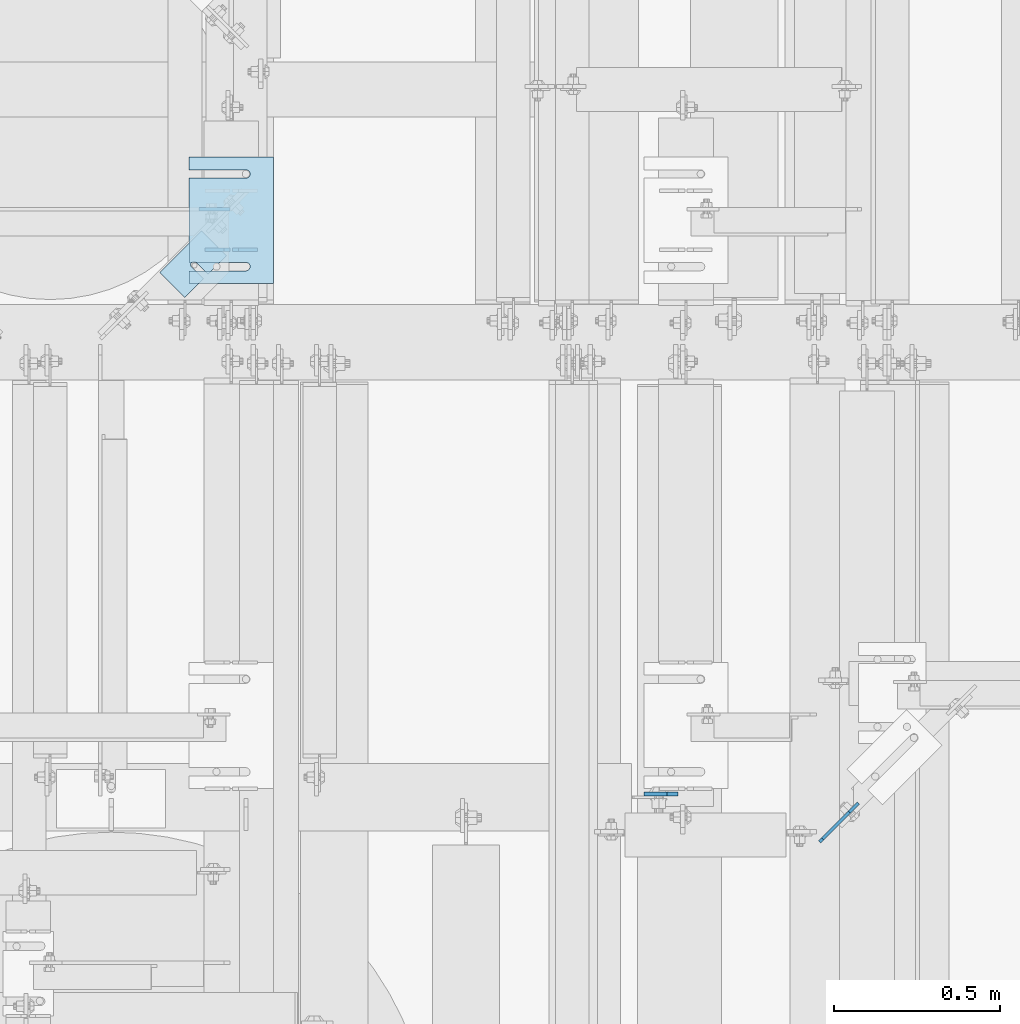
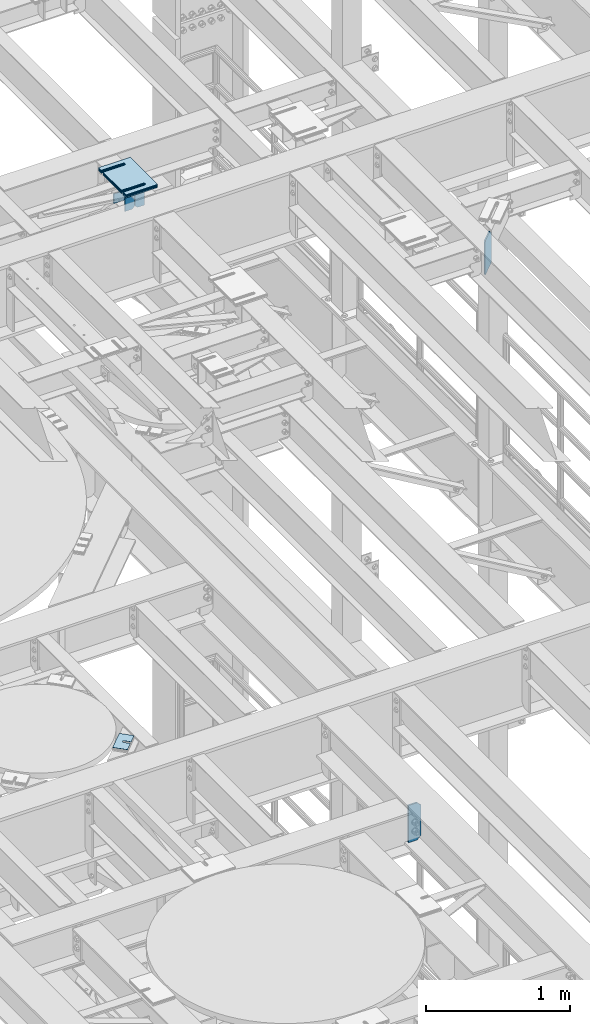
# One storey, part 1718 of 1876: 12 plates, 10 elements without a shape of their own.
"""IFC2X3 building model written with IfcOpenShell, lengths in millimetres."""

from ifc_helpers import new_model, si_unit, frame, origin_with_axes, place, context, subcontext, project, spatial, faceted_brep, material, type_object, element, aggregate, save


model = new_model("IFC2X3")

# Units and contexts
model_context = context("Model", 3, precision=1e-05, world=origin_with_axes())
body_context = subcontext(model_context, "Body", "Model", "MODEL_VIEW")
ifc_project = project(units=[si_unit("LENGTHUNIT", "METRE", prefix="MILLI"), si_unit("AREAUNIT", "SQUARE_METRE"), si_unit("VOLUMEUNIT", "CUBIC_METRE"), si_unit("MASSUNIT", "GRAM", prefix="KILO"), si_unit("TIMEUNIT", "SECOND"), si_unit("PLANEANGLEUNIT", "RADIAN"), si_unit("SOLIDANGLEUNIT", "STERADIAN"), si_unit("THERMODYNAMICTEMPERATUREUNIT", "DEGREE_CELSIUS"), si_unit("LUMINOUSINTENSITYUNIT", "LUMEN")], contexts=[model_context])

# Site, building, storey
site_placement = place(None, origin_with_axes())
site = spatial("IfcSite", under=ifc_project, at=site_placement, CompositionType="ELEMENT")
building_placement = place(site_placement, origin_with_axes())
building = spatial("IfcBuilding", under=site, at=building_placement, Name="Undefined", CompositionType="ELEMENT")
storey_placement = place(building_placement, origin_with_axes())
storey = spatial("IfcBuildingStorey", under=building, at=storey_placement, Name="Undefined", CompositionType="ELEMENT", Elevation=0.0)

# Assembly, plates
assembly_1_placement = place(storey_placement, origin_with_axes())
assembly_1 = element("IfcElementAssembly", 1, at=assembly_1_placement, inside=storey, Name="BEAM", AssemblyPlace="NOTDEFINED", PredefinedType="RIGID_FRAME")
ifc_material = material(Name="STEEL/A36")
plate_type_1 = type_object("IfcPlateType", PredefinedType="NOTDEFINED")
plate_1_placement = place(assembly_1_placement, frame((3813.17530602581, 7898.88122576401, 17792.7), z_axis=(0.0, 0.0, 1.0), x_axis=(-1.0, 0.0, 0.0)))
plate_1 = element("IfcPlate", 2, at=plate_1_placement, type_object=plate_type_1, material=ifc_material, Name="PLATE", context=body_context, shape_type="Brep", body=[
    faceted_brep([(0.0, -4.76249999999982, 0.0), (0.0, -4.76249999999982, 180.975006103516), (0.0, 4.76249999999982, 180.975006103516), (0.0, 4.76249999999982, 0.0), (57.1499977111816, -4.76249999999982, 180.975006103516), (57.1499977111816, 4.76249999999982, 180.975006103516), (76.1999969482422, -4.76249999999982, 161.925006866455), (76.1999969482422, 4.76249999999982, 161.925006866455), (76.1999969482422, -4.76249999999982, 19.0499992370605), (76.1999969482422, 4.76249999999982, 19.0499992370605), (57.1499977111816, -4.76249999999982, 0.0), (57.1499977111816, 4.76249999999982, 0.0)], [[[0, 1, 2, 3]], [[1, 4, 5, 2]], [[4, 6, 7, 5]], [[6, 8, 9, 7]], [[8, 10, 11, 9]], [[10, 0, 3, 11]], [[5, 7, 9, 11, 3, 2]], [[10, 8, 6, 4, 1, 0]]]),
])
plate_2_placement = place(assembly_1_placement, frame((3730.62530602581, 7898.88122576401, 17792.7), z_axis=(0.0, 0.0, 1.0), x_axis=(-1.0, 0.0, 0.0)))
plate_2 = element("IfcPlate", 3, at=plate_2_placement, type_object=plate_type_1, material=ifc_material, Name="PLATE", context=body_context, shape_type="Brep", body=[
    faceted_brep([(0.0, -4.76249999999982, 19.0499992370605), (0.0, -4.76249999999982, 161.925006866455), (0.0, 4.76249999999982, 161.925006866455), (0.0, 4.76249999999982, 19.0499992370605), (19.0499992370605, -4.76249999999982, 180.975006103516), (19.0499992370605, 4.76249999999982, 180.975006103516), (76.1999969482422, -4.76249999999982, 180.975006103516), (76.1999969482422, 4.76249999999982, 180.975006103516), (76.1999969482422, -4.76250000000073, 0.0), (76.1999969482422, 4.76250000000073, 0.0), (19.0499992370605, -4.76249999999982, 0.0), (19.0499992370605, 4.76249999999982, 0.0)], [[[0, 1, 2, 3]], [[1, 4, 5, 2]], [[4, 6, 7, 5]], [[6, 8, 9, 7]], [[8, 10, 11, 9]], [[10, 0, 3, 11]], [[5, 7, 9, 11, 3, 2]], [[10, 8, 6, 4, 1, 0]]]),
])
plate_type_2 = type_object("IfcPlateType", PredefinedType="NOTDEFINED")
plate_3_placement = place(assembly_1_placement, frame((3636.43608330879, 8021.04472066874, 17872.884434622), z_axis=(1.0, 0.0, 0.0), x_axis=(0.0, 0.0, -1.0)))
plate_3 = element("IfcPlate", 4, at=plate_3_placement, type_object=plate_type_2, material=ifc_material, Name="PLATE", context=body_context, shape_type="Brep", body=[
    faceted_brep([(0.0, -4.76249999999982, 0.0), (-4.72590436402243e-05, -4.76250000001801, 94.1892242431759), (-4.72590436402243e-05, 4.76249999998163, 94.1892242431773), (0.0, 4.76249999999982, 0.0), (67.4843873978753, -4.76250000001892, 94.1892820322919), (67.4843873978753, 4.76249999998072, 94.1892820322932), (80.1843933793753, -4.76250000001528, 81.4892930984493), (80.1843933793753, 4.76249999998436, 81.4892930984511), (80.1844329834057, -4.76249999999982, 1.16870069177821e-10), (80.1844329834057, 4.76249999999982, 1.18689058581367e-10)], [[[0, 1, 2, 3]], [[1, 4, 5, 2]], [[4, 6, 7, 5]], [[6, 8, 9, 7]], [[8, 0, 3, 9]], [[5, 7, 9, 3, 2]], [[8, 6, 4, 1, 0]]]),
])
aggregate(assembly_1, [plate_1, plate_2, plate_3])

# Assembly, plate
assembly_2_placement = place(storey_placement, origin_with_axes())
assembly_2 = element("IfcElementAssembly", 5, at=assembly_2_placement, inside=storey, Name="BEAM", AssemblyPlace="NOTDEFINED", PredefinedType="RIGID_FRAME")
plate_type_3 = type_object("IfcPlateType", PredefinedType="NOTDEFINED")
plate_4_placement = place(assembly_2_placement, frame((5080.79375, 6257.13125009537, 12974.6375), z_axis=(0.0, 0.0, 1.0), x_axis=(-1.0, 0.0, 0.0)))
plate_4 = element("IfcPlate", 6, at=plate_4_placement, type_object=plate_type_3, material=ifc_material, Name="PLATE", context=body_context, shape_type="Brep", body=[
    faceted_brep([(0.0, -6.34999999999991, 31.75), (-1.81898940354586e-12, -6.34999999999991, 284.162506103516), (1.81898940354586e-12, 6.35000000000173, 284.162506103516), (0.0, 6.34999999999991, 31.75), (31.7499999999927, -6.34999999999991, 315.912506103516), (31.7499999999982, 6.35000000000309, 315.912506103516), (101.599998474121, -6.35000000000036, 315.912506103516), (101.599998474121, 6.35000000000036, 315.912506103516), (101.599998474121, -6.35000000000036, 0.0), (101.599998474121, 6.35000000000036, 0.0), (31.75, -6.34999999999991, 0.0), (31.75, 6.34999999999991, 0.0)], [[[0, 1, 2, 3]], [[1, 4, 5, 2]], [[4, 6, 7, 5]], [[6, 8, 9, 7]], [[8, 10, 11, 9]], [[10, 0, 3, 11]], [[5, 7, 9, 11, 3, 2]], [[10, 8, 6, 4, 1, 0]]]),
])
aggregate(assembly_2, [plate_4])

assembly_3_placement = place(storey_placement, origin_with_axes())
assembly_3 = element("IfcElementAssembly", 7, at=assembly_3_placement, inside=storey, Name="SHIM PLATE", AssemblyPlace="NOTDEFINED", PredefinedType="RIGID_FRAME")
plate_type_4 = type_object("IfcPlateType", PredefinedType="NOTDEFINED")
plate_5_placement = place(assembly_3_placement, frame((3860.80063238647, 8178.20543274993, 18007.0115), z_axis=(-1.0, 0.0, 0.0), x_axis=(0.0, -1.0, 0.0)))
plate_5 = element("IfcPlate", 8, at=plate_5_placement, type_object=plate_type_4, material=ifc_material, Name="SHIM PLATE", context=body_context, shape_type="Brep", body=[
    faceted_brep([(38.1710562683074, -1.58750000000146, 253.999557495119), (38.1732778844053, -1.58750000000146, 82.6182316462764), (38.1732778844053, 1.58750000000146, 82.6182316462764), (38.1710562683074, 1.58750000000146, 253.999557495119), (39.8747477728821, -1.58750000000146, 76.2682283464169), (39.8747477728821, 1.58750000000146, 76.2682283464169), (44.523266268131, -1.58750000000146, 71.6196998169826), (44.523266268131, 1.58750000000146, 71.6196998169826), (50.8732658952267, -1.58750000000146, 69.9182162215529), (50.8732658952267, 1.58750000000146, 69.9182162215529), (57.2232684284982, -1.58750000000146, 71.6196889709886), (57.2232684284982, 1.58750000000146, 71.6196889709886), (61.8717948635667, -1.58750000000146, 76.2682095606051), (61.8717948635667, 1.58750000000146, 76.2682095606051), (63.5732755980398, -1.58750000000146, 82.6182099542939), (63.5732755980398, 1.58750000000146, 82.6182099542939), (63.5710539816291, -1.58750000000146, 253.999557596195), (63.5710539816291, 1.58750000000146, 253.99955749512), (9.09494701772928e-13, -1.58750000000146, 4.54747350886464e-13), (1.89071320164658e-05, -1.58750000000146, 253.999557495117), (1.89071320164658e-05, 1.58750000000146, 253.999557495117), (9.09494701772928e-13, 1.58750000000146, 4.54747350886464e-13), (380.998474121094, -1.58750000000146, -2.41016095969826e-11), (380.998474121094, 1.58750000000146, -2.41016095969826e-11), (380.998504638661, -1.58750000000146, 253.999557495133), (380.998504638661, 1.58750000000146, 253.999557495133), (342.971054337228, 1.58750000000146, 253.999557495132), (342.971054337228, -1.58750000000146, 253.999557596208), (342.973275782132, 1.58750000000146, 82.6182252130961), (342.973275782132, -1.58750000000146, 82.6182252130961), (341.271801399192, 1.58750000000146, 76.2682205744086), (341.271801399192, -1.58750000000146, 76.2682205744086), (336.623277411347, 1.58750000000146, 71.6196940636119), (336.623277411347, -1.58750000000146, 71.6196940636119), (330.273273696123, 1.58750000000146, 69.9182162342554), (330.273273696123, -1.58750000000146, 69.9182162342554), (323.923270846187, 1.58750000000146, 71.6196972929051), (323.923270846187, -1.58750000000146, 71.6196972929051), (319.274749222349, 1.58750000000146, 76.2682261677069), (319.274749222349, -1.58750000000146, 76.2682261677069), (317.573278068704, 1.58750000000146, 82.6182316716777), (317.573278068704, -1.58750000000146, 82.6182316716777), (317.571056623908, -1.58750000000146, 253.99955749513), (317.571056623908, 1.58750000000146, 253.99955749513)], [[[0, 1, 2, 3]], [[4, 5, 2, 1]], [[6, 7, 5, 4]], [[8, 9, 7, 6]], [[10, 11, 9, 8]], [[12, 13, 11, 10]], [[14, 15, 13, 12]], [[16, 17, 15, 14]], [[18, 19, 20, 21]], [[22, 18, 21, 23]], [[24, 22, 23, 25]], [[24, 25, 26, 27]], [[27, 26, 28, 29]], [[29, 28, 30, 31]], [[31, 30, 32, 33]], [[33, 32, 34, 35]], [[35, 34, 36, 37]], [[37, 36, 38, 39]], [[39, 38, 40, 41]], [[42, 41, 40, 43]], [[12, 10, 8, 6, 4, 1, 0, 19, 18, 22, 24, 27, 29, 31, 33, 35, 37, 39, 41, 42, 16, 14]], [[20, 19, 0, 3]], [[43, 40, 38, 36, 34, 32, 30, 28, 26, 25, 23, 21, 20, 3, 2, 5, 7, 9, 11, 13, 15, 17]], [[42, 43, 17, 16]]]),
])
aggregate(assembly_3, [plate_5])

assembly_4_placement = place(storey_placement, origin_with_axes())
assembly_4 = element("IfcElementAssembly", 9, at=assembly_4_placement, inside=storey, Name="SHIM PLATE", AssemblyPlace="NOTDEFINED", PredefinedType="RIGID_FRAME")
plate_6_placement = place(assembly_4_placement, frame((3860.80063238647, 8178.20543274993, 18003.8365), z_axis=(-1.0, 0.0, 0.0), x_axis=(0.0, -1.0, 0.0)))
plate_6 = element("IfcPlate", 10, at=plate_6_placement, type_object=plate_type_4, material=ifc_material, Name="SHIM PLATE", context=body_context, shape_type="Brep", body=[
    faceted_brep([(38.1710562683074, -1.58750000000146, 253.999557495119), (38.1732778844053, -1.58750000000146, 82.6182316462764), (38.1732778844053, 1.58750000000146, 82.6182316462764), (38.1710562683074, 1.58750000000146, 253.999557495119), (39.8747477728821, -1.58750000000146, 76.2682283464169), (39.8747477728821, 1.58750000000146, 76.2682283464169), (44.523266268131, -1.58750000000146, 71.6196998169826), (44.523266268131, 1.58750000000146, 71.6196998169826), (50.8732658952267, -1.58750000000146, 69.9182162215529), (50.8732658952267, 1.58750000000146, 69.9182162215529), (57.2232684284982, -1.58750000000146, 71.6196889709886), (57.2232684284982, 1.58750000000146, 71.6196889709886), (61.8717948635667, -1.58750000000146, 76.2682095606051), (61.8717948635667, 1.58750000000146, 76.2682095606051), (63.5732755980398, -1.58750000000146, 82.6182099542939), (63.5732755980398, 1.58750000000146, 82.6182099542939), (63.5710539816291, -1.58750000000146, 253.999557596195), (63.5710539816291, 1.58750000000146, 253.99955749512), (9.09494701772928e-13, -1.58750000000146, 4.54747350886464e-13), (1.89071320164658e-05, -1.58750000000146, 253.999557495117), (1.89071320164658e-05, 1.58750000000146, 253.999557495117), (9.09494701772928e-13, 1.58750000000146, 4.54747350886464e-13), (380.998474121094, -1.58750000000146, -2.41016095969826e-11), (380.998474121094, 1.58750000000146, -2.41016095969826e-11), (380.998504638661, -1.58750000000146, 253.999557495133), (380.998504638661, 1.58750000000146, 253.999557495133), (342.971054337228, 1.58750000000146, 253.999557495132), (342.971054337228, -1.58750000000146, 253.999557596208), (342.973275782132, 1.58750000000146, 82.6182252130961), (342.973275782132, -1.58750000000146, 82.6182252130961), (341.271801399192, 1.58750000000146, 76.2682205744086), (341.271801399192, -1.58750000000146, 76.2682205744086), (336.623277411347, 1.58750000000146, 71.6196940636119), (336.623277411347, -1.58750000000146, 71.6196940636119), (330.273273696123, 1.58750000000146, 69.9182162342554), (330.273273696123, -1.58750000000146, 69.9182162342554), (323.923270846187, 1.58750000000146, 71.6196972929051), (323.923270846187, -1.58750000000146, 71.6196972929051), (319.274749222349, 1.58750000000146, 76.2682261677069), (319.274749222349, -1.58750000000146, 76.2682261677069), (317.573278068704, 1.58750000000146, 82.6182316716777), (317.573278068704, -1.58750000000146, 82.6182316716777), (317.571056623908, -1.58750000000146, 253.99955749513), (317.571056623908, 1.58750000000146, 253.99955749513)], [[[0, 1, 2, 3]], [[4, 5, 2, 1]], [[6, 7, 5, 4]], [[8, 9, 7, 6]], [[10, 11, 9, 8]], [[12, 13, 11, 10]], [[14, 15, 13, 12]], [[16, 17, 15, 14]], [[18, 19, 20, 21]], [[22, 18, 21, 23]], [[24, 22, 23, 25]], [[24, 25, 26, 27]], [[27, 26, 28, 29]], [[29, 28, 30, 31]], [[31, 30, 32, 33]], [[33, 32, 34, 35]], [[35, 34, 36, 37]], [[37, 36, 38, 39]], [[39, 38, 40, 41]], [[42, 41, 40, 43]], [[12, 10, 8, 6, 4, 1, 0, 19, 18, 22, 24, 27, 29, 31, 33, 35, 37, 39, 41, 42, 16, 14]], [[20, 19, 0, 3]], [[43, 40, 38, 36, 34, 32, 30, 28, 26, 25, 23, 21, 20, 3, 2, 5, 7, 9, 11, 13, 15, 17]], [[42, 43, 17, 16]]]),
])
aggregate(assembly_4, [plate_6])

assembly_5_placement = place(storey_placement, origin_with_axes())
assembly_5 = element("IfcElementAssembly", 11, at=assembly_5_placement, inside=storey, Name="SHIM PLATE", AssemblyPlace="NOTDEFINED", PredefinedType="RIGID_FRAME")
plate_type_5 = type_object("IfcPlateType", PredefinedType="NOTDEFINED")
plate_7_placement = place(assembly_5_placement, frame((3860.80063238647, 8178.20543274993, 18009.3925), z_axis=(-1.0, 0.0, 0.0), x_axis=(0.0, -1.0, 0.0)))
plate_7 = element("IfcPlate", 12, at=plate_7_placement, type_object=plate_type_5, material=ifc_material, Name="SHIM PLATE", context=body_context, shape_type="Brep", body=[
    faceted_brep([(38.1710562683074, -0.793499999999767, 253.999557495119), (38.1732778844053, -0.793499999999767, 82.6182316462764), (38.1732778844053, 0.793499999999767, 82.6182316462764), (38.1710562683074, 0.793499999999767, 253.999557495119), (39.8747477728821, -0.793499999999767, 76.2682283464169), (39.8747477728821, 0.793499999999767, 76.2682283464169), (44.523266268131, -0.793499999999767, 71.6196998169826), (44.523266268131, 0.793499999999767, 71.6196998169826), (50.8732658952267, -0.793499999999767, 69.9182162215529), (50.8732658952267, 0.793499999999767, 69.9182162215529), (57.2232684284982, -0.793499999999767, 71.6196889709886), (57.2232684284982, 0.793499999999767, 71.6196889709886), (61.8717948635667, -0.793499999999767, 76.2682095606051), (61.8717948635667, 0.793499999999767, 76.2682095606051), (63.5732755980398, -0.793499999999767, 82.6182099542939), (63.5732755980398, 0.793499999999767, 82.6182099542939), (63.5710539816291, -0.793499999999767, 253.999557596195), (63.5710539816291, 0.793499999999767, 253.99955749512), (9.09494701772928e-13, -0.793499999999767, 0.0), (1.89070156011439e-05, -0.793499999999767, 253.999557495117), (1.89070156011439e-05, 0.793499999999767, 253.999557495117), (9.09494701772928e-13, 0.793499999999767, 0.0), (380.998474121094, -0.793499999999767, -2.41016095969826e-11), (380.998474121094, 0.793499999999767, -2.41016095969826e-11), (380.998504638661, -0.793499999999767, 253.999557495133), (380.998504638661, 0.793499999999767, 253.999557495133), (342.971054337228, 0.793499999999767, 253.999557495132), (342.971054337228, -0.793499999999767, 253.999557596208), (342.973275782132, 0.793499999999767, 82.6182252130961), (342.973275782132, -0.793499999999767, 82.6182252130961), (341.271801399192, 0.793499999999767, 76.2682205744086), (341.271801399192, -0.793499999999767, 76.2682205744086), (336.623277411347, 0.793499999999767, 71.6196940636119), (336.623277411347, -0.793499999999767, 71.6196940636119), (330.273273696123, 0.793499999999767, 69.9182162342554), (330.273273696123, -0.793499999999767, 69.9182162342554), (323.923270846187, 0.793499999999767, 71.6196972929051), (323.923270846187, -0.793499999999767, 71.6196972929051), (319.274749222349, 0.793499999999767, 76.2682261677069), (319.274749222349, -0.793499999999767, 76.2682261677069), (317.573278068704, 0.793499999999767, 82.6182316716777), (317.573278068704, -0.793499999999767, 82.6182316716777), (317.571056623908, -0.793499999999767, 253.99955749513), (317.571056623908, 0.793499999999767, 253.99955749513)], [[[0, 1, 2, 3]], [[4, 5, 2, 1]], [[6, 7, 5, 4]], [[8, 9, 7, 6]], [[10, 11, 9, 8]], [[12, 13, 11, 10]], [[14, 15, 13, 12]], [[16, 17, 15, 14]], [[18, 19, 20, 21]], [[22, 18, 21, 23]], [[24, 22, 23, 25]], [[24, 25, 26, 27]], [[27, 26, 28, 29]], [[29, 28, 30, 31]], [[31, 30, 32, 33]], [[33, 32, 34, 35]], [[35, 34, 36, 37]], [[37, 36, 38, 39]], [[39, 38, 40, 41]], [[42, 41, 40, 43]], [[12, 10, 8, 6, 4, 1, 0, 19, 18, 22, 24, 27, 29, 31, 33, 35, 37, 39, 41, 42, 16, 14]], [[20, 19, 0, 3]], [[43, 40, 38, 36, 34, 32, 30, 28, 26, 25, 23, 21, 20, 3, 2, 5, 7, 9, 11, 13, 15, 17]], [[42, 43, 17, 16]]]),
])
aggregate(assembly_5, [plate_7])

assembly_6_placement = place(storey_placement, origin_with_axes())
assembly_6 = element("IfcElementAssembly", 13, at=assembly_6_placement, inside=storey, Name="SHIM PLATE", AssemblyPlace="NOTDEFINED", PredefinedType="RIGID_FRAME")
plate_type_6 = type_object("IfcPlateType", PredefinedType="NOTDEFINED")
plate_8_placement = place(assembly_6_placement, frame((3860.80063238647, 8178.20543274993, 17999.868), z_axis=(-1.0, 0.0, 0.0), x_axis=(0.0, -1.0, 0.0)))
plate_8 = element("IfcPlate", 14, at=plate_8_placement, type_object=plate_type_6, material=ifc_material, Name="SHIM PLATE", context=body_context, shape_type="Brep", body=[
    faceted_brep([(38.1710562683056, -2.38100000000122, 253.999557495119), (38.1732778844034, -2.38100000000122, 82.6182316462764), (38.1732778844034, 2.38100000000122, 82.6182316462764), (38.1710562683056, 2.38100000000122, 253.999557495119), (39.8747477728803, -2.38100000000122, 76.2682283464169), (39.8747477728803, 2.38100000000122, 76.2682283464169), (44.5232662681292, -2.38100000000122, 71.6196998169826), (44.5232662681292, 2.38100000000122, 71.6196998169826), (50.8732658952249, -2.38100000000122, 69.9182162215529), (50.8732658952249, 2.38100000000122, 69.9182162215529), (57.2232684284963, -2.38100000000122, 71.6196889709886), (57.2232684284963, 2.38100000000122, 71.6196889709886), (61.8717948635649, -2.38100000000122, 76.2682095606051), (61.8717948635649, 2.38100000000122, 76.2682095606051), (63.573275598038, -2.38100000000122, 82.6182099542939), (63.573275598038, 2.38100000000122, 82.6182099542939), (63.5710539816273, -2.38100000000122, 253.999557596195), (63.5710539816273, 2.38100000000122, 253.99955749512), (0.0, -2.38100000000122, 4.54747350886464e-13), (1.89072484317876e-05, -2.38100000000122, 253.999557495117), (1.89072484317876e-05, 2.38100000000122, 253.999557495117), (0.0, 2.38100000000122, 4.54747350886464e-13), (380.998474121094, -2.38100000000122, -2.41016095969826e-11), (380.998474121094, 2.38100000000122, -2.41016095969826e-11), (380.998504638661, -2.38100000000122, 253.999557495133), (380.998504638661, 2.38100000000122, 253.999557495133), (342.971054337227, 2.38100000000122, 253.999557495132), (342.971054337227, -2.38100000000122, 253.999557596208), (342.97327578213, 2.38100000000122, 82.6182252130961), (342.97327578213, -2.38100000000122, 82.6182252130961), (341.27180139919, 2.38100000000122, 76.2682205744086), (341.27180139919, -2.38100000000122, 76.2682205744086), (336.623277411345, 2.38100000000122, 71.6196940636119), (336.623277411345, -2.38100000000122, 71.6196940636119), (330.273273696122, 2.38100000000122, 69.9182162342554), (330.273273696122, -2.38100000000122, 69.9182162342554), (323.923270846185, 2.38100000000122, 71.6196972929051), (323.923270846185, -2.38100000000122, 71.6196972929051), (319.274749222347, 2.38100000000122, 76.2682261677069), (319.274749222347, -2.38100000000122, 76.2682261677069), (317.573278068702, 2.38100000000122, 82.6182316716777), (317.573278068702, -2.38100000000122, 82.6182316716777), (317.571056623906, -2.38100000000122, 253.99955749513), (317.571056623906, 2.38100000000122, 253.99955749513)], [[[0, 1, 2, 3]], [[4, 5, 2, 1]], [[6, 7, 5, 4]], [[8, 9, 7, 6]], [[10, 11, 9, 8]], [[12, 13, 11, 10]], [[14, 15, 13, 12]], [[16, 17, 15, 14]], [[18, 19, 20, 21]], [[22, 18, 21, 23]], [[24, 22, 23, 25]], [[24, 25, 26, 27]], [[27, 26, 28, 29]], [[29, 28, 30, 31]], [[31, 30, 32, 33]], [[33, 32, 34, 35]], [[35, 34, 36, 37]], [[37, 36, 38, 39]], [[39, 38, 40, 41]], [[42, 41, 40, 43]], [[12, 10, 8, 6, 4, 1, 0, 19, 18, 22, 24, 27, 29, 31, 33, 35, 37, 39, 41, 42, 16, 14]], [[20, 19, 0, 3]], [[43, 40, 38, 36, 34, 32, 30, 28, 26, 25, 23, 21, 20, 3, 2, 5, 7, 9, 11, 13, 15, 17]], [[42, 43, 17, 16]]]),
])
aggregate(assembly_6, [plate_8])

assembly_7_placement = place(storey_placement, origin_with_axes())
assembly_7 = element("IfcElementAssembly", 15, at=assembly_7_placement, inside=storey, Name="SHIM PLATE", AssemblyPlace="NOTDEFINED", PredefinedType="RIGID_FRAME")
plate_9_placement = place(assembly_7_placement, frame((3860.80063238646, 8178.20543274993, 17995.106), z_axis=(-1.0, 0.0, 0.0), x_axis=(0.0, -1.0, 0.0)))
plate_9 = element("IfcPlate", 16, at=plate_9_placement, type_object=plate_type_6, material=ifc_material, Name="SHIM PLATE", context=body_context, shape_type="Brep", body=[
    faceted_brep([(38.1710562683056, -2.38100000000122, 253.999557495119), (38.1732778844034, -2.38100000000122, 82.6182316462764), (38.1732778844034, 2.38100000000122, 82.6182316462764), (38.1710562683056, 2.38100000000122, 253.999557495119), (39.8747477728803, -2.38100000000122, 76.2682283464169), (39.8747477728803, 2.38100000000122, 76.2682283464169), (44.5232662681292, -2.38100000000122, 71.6196998169826), (44.5232662681292, 2.38100000000122, 71.6196998169826), (50.8732658952249, -2.38100000000122, 69.9182162215529), (50.8732658952249, 2.38100000000122, 69.9182162215529), (57.2232684284963, -2.38100000000122, 71.6196889709886), (57.2232684284963, 2.38100000000122, 71.6196889709886), (61.8717948635649, -2.38100000000122, 76.2682095606051), (61.8717948635649, 2.38100000000122, 76.2682095606051), (63.573275598038, -2.38100000000122, 82.6182099542939), (63.573275598038, 2.38100000000122, 82.6182099542939), (63.5710539816273, -2.38100000000122, 253.999557596195), (63.5710539816273, 2.38100000000122, 253.99955749512), (0.0, -2.38100000000122, 4.54747350886464e-13), (1.89072484317876e-05, -2.38100000000122, 253.999557495117), (1.89072484317876e-05, 2.38100000000122, 253.999557495117), (0.0, 2.38100000000122, 4.54747350886464e-13), (380.998474121094, -2.38100000000122, -2.41016095969826e-11), (380.998474121094, 2.38100000000122, -2.41016095969826e-11), (380.998504638661, -2.38100000000122, 253.999557495133), (380.998504638661, 2.38100000000122, 253.999557495133), (342.971054337227, 2.38100000000122, 253.999557495132), (342.971054337227, -2.38100000000122, 253.999557596208), (342.97327578213, 2.38100000000122, 82.6182252130961), (342.97327578213, -2.38100000000122, 82.6182252130961), (341.27180139919, 2.38100000000122, 76.2682205744086), (341.27180139919, -2.38100000000122, 76.2682205744086), (336.623277411345, 2.38100000000122, 71.6196940636119), (336.623277411345, -2.38100000000122, 71.6196940636119), (330.273273696122, 2.38100000000122, 69.9182162342554), (330.273273696122, -2.38100000000122, 69.9182162342554), (323.923270846185, 2.38100000000122, 71.6196972929051), (323.923270846185, -2.38100000000122, 71.6196972929051), (319.274749222347, 2.38100000000122, 76.2682261677069), (319.274749222347, -2.38100000000122, 76.2682261677069), (317.573278068702, 2.38100000000122, 82.6182316716777), (317.573278068702, -2.38100000000122, 82.6182316716777), (317.571056623906, -2.38100000000122, 253.99955749513), (317.571056623906, 2.38100000000122, 253.99955749513)], [[[0, 1, 2, 3]], [[4, 5, 2, 1]], [[6, 7, 5, 4]], [[8, 9, 7, 6]], [[10, 11, 9, 8]], [[12, 13, 11, 10]], [[14, 15, 13, 12]], [[16, 17, 15, 14]], [[18, 19, 20, 21]], [[22, 18, 21, 23]], [[24, 22, 23, 25]], [[24, 25, 26, 27]], [[27, 26, 28, 29]], [[29, 28, 30, 31]], [[31, 30, 32, 33]], [[33, 32, 34, 35]], [[35, 34, 36, 37]], [[37, 36, 38, 39]], [[39, 38, 40, 41]], [[42, 41, 40, 43]], [[12, 10, 8, 6, 4, 1, 0, 19, 18, 22, 24, 27, 29, 31, 33, 35, 37, 39, 41, 42, 16, 14]], [[20, 19, 0, 3]], [[43, 40, 38, 36, 34, 32, 30, 28, 26, 25, 23, 21, 20, 3, 2, 5, 7, 9, 11, 13, 15, 17]], [[42, 43, 17, 16]]]),
])
aggregate(assembly_7, [plate_9])

assembly_8_placement = place(storey_placement, origin_with_axes())
assembly_8 = element("IfcElementAssembly", 17, at=assembly_8_placement, inside=storey, Name="SHIM PLATE", AssemblyPlace="NOTDEFINED", PredefinedType="RIGID_FRAME")
plate_type_7 = type_object("IfcPlateType", PredefinedType="NOTDEFINED")
plate_10_placement = place(assembly_8_placement, frame((3860.80063238646, 8178.20543274993, 17987.9625), z_axis=(-1.0, 0.0, 0.0), x_axis=(0.0, -1.0, 0.0)))
plate_10 = element("IfcPlate", 18, at=plate_10_placement, type_object=plate_type_7, material=ifc_material, Name="SHIM PLATE", context=body_context, shape_type="Brep", body=[
    faceted_brep([(38.1710562683074, -4.76250000000073, 253.999557495119), (38.1732778844053, -4.76250000000073, 82.6182316462764), (38.1732778844053, 4.76250000000073, 82.6182316462764), (38.1710562683074, 4.76250000000073, 253.999557495119), (39.8747477728821, -4.76250000000073, 76.2682283464169), (39.8747477728821, 4.76250000000073, 76.2682283464169), (44.523266268131, -4.76250000000073, 71.6196998169826), (44.523266268131, 4.76250000000073, 71.6196998169826), (50.8732658952267, -4.76250000000073, 69.9182162215529), (50.8732658952267, 4.76250000000073, 69.9182162215529), (57.2232684284982, -4.76250000000073, 71.6196889709886), (57.2232684284982, 4.76250000000073, 71.6196889709886), (61.8717948635667, -4.76250000000073, 76.2682095606051), (61.8717948635667, 4.76250000000073, 76.2682095606051), (63.5732755980398, -4.76250000000073, 82.6182099542939), (63.5732755980398, 4.76250000000073, 82.6182099542939), (63.5710539816291, -4.76250000000073, 253.999557596195), (63.5710539816291, 4.76250000000073, 253.99955749512), (0.0, -4.76249999999982, 0.0), (1.89073648471094e-05, -4.76250000000073, 253.999557495117), (1.89073648471094e-05, 4.76250000000073, 253.999557495117), (0.0, 4.76249999999982, 0.0), (380.998474121094, -4.76250000000073, -2.41016095969826e-11), (380.998474121094, 4.76250000000073, -2.41016095969826e-11), (380.998504638661, -4.76250000000073, 253.999557495133), (380.998504638661, 4.76250000000073, 253.999557495133), (342.971054337228, 4.76250000000073, 253.999557495132), (342.971054337228, -4.76250000000073, 253.999557596208), (342.973275782132, 4.76250000000073, 82.6182252130961), (342.973275782132, -4.76250000000073, 82.6182252130961), (341.271801399192, 4.76250000000073, 76.2682205744086), (341.271801399192, -4.76250000000073, 76.2682205744086), (336.623277411347, 4.76250000000073, 71.6196940636119), (336.623277411347, -4.76250000000073, 71.6196940636119), (330.273273696123, 4.76250000000073, 69.9182162342554), (330.273273696123, -4.76250000000073, 69.9182162342554), (323.923270846187, 4.76250000000073, 71.6196972929051), (323.923270846187, -4.76250000000073, 71.6196972929051), (319.274749222349, 4.76250000000073, 76.2682261677069), (319.274749222349, -4.76250000000073, 76.2682261677069), (317.573278068704, 4.76250000000073, 82.6182316716777), (317.573278068704, -4.76250000000073, 82.6182316716777), (317.571056623908, -4.76250000000073, 253.99955749513), (317.571056623908, 4.76250000000073, 253.99955749513)], [[[0, 1, 2, 3]], [[4, 5, 2, 1]], [[6, 7, 5, 4]], [[8, 9, 7, 6]], [[10, 11, 9, 8]], [[12, 13, 11, 10]], [[14, 15, 13, 12]], [[16, 17, 15, 14]], [[18, 19, 20, 21]], [[22, 18, 21, 23]], [[24, 22, 23, 25]], [[24, 25, 26, 27]], [[27, 26, 28, 29]], [[29, 28, 30, 31]], [[31, 30, 32, 33]], [[33, 32, 34, 35]], [[35, 34, 36, 37]], [[37, 36, 38, 39]], [[39, 38, 40, 41]], [[42, 41, 40, 43]], [[12, 10, 8, 6, 4, 1, 0, 19, 18, 22, 24, 27, 29, 31, 33, 35, 37, 39, 41, 42, 16, 14]], [[20, 19, 0, 3]], [[43, 40, 38, 36, 34, 32, 30, 28, 26, 25, 23, 21, 20, 3, 2, 5, 7, 9, 11, 13, 15, 17]], [[42, 43, 17, 16]]]),
])
aggregate(assembly_8, [plate_10])

assembly_9_placement = place(storey_placement, origin_with_axes())
assembly_9 = element("IfcElementAssembly", 19, at=assembly_9_placement, inside=storey, Name="SHIM PLATE", AssemblyPlace="NOTDEFINED", PredefinedType="RIGID_FRAME")
plate_type_8 = type_object("IfcPlateType", PredefinedType="NOTDEFINED")
plate_11_placement = place(assembly_9_placement, frame((3518.69760703957, 7830.37621876371, 13335.7925), z_axis=(0.707118099095974, 0.707095463095965, 0.0), x_axis=(0.707095463095965, -0.707118099095973, 0.0)))
plate_11 = element("IfcPlate", 20, at=plate_11_placement, type_object=plate_type_8, material=ifc_material, Name="SHIM PLATE", context=body_context, shape_type="Brep", body=[
    faceted_brep([(106.56854125413, -0.793499999999767, 79.3765579294427), (106.56854125413, 0.793499999999767, 79.3765579294427), (58.950614772988, 0.793499999999767, 79.374431191693), (58.950614772988, -0.793499999999767, 79.374431191693), (52.9160762669253, 0.793499999999767, 79.5269726944375), (52.9160762669253, -0.793499999999767, 79.5269726944375), (48.0867887969507, 0.793499999999767, 83.1486996890612), (48.0867887969507, -0.793499999999767, 83.1486996890612), (46.2503144929269, 0.793499999999767, 88.8990288989298), (46.2503144929269, -0.793499999999767, 88.8990288989298), (48.0864248405542, 0.793499999999767, 94.6494743323324), (48.0864248405542, -0.793499999999767, 94.6494743323324), (52.9154830726984, 0.793499999999767, 98.2715069773753), (52.9154830726984, -0.793499999999767, 98.2715069773753), (58.9500119119384, 0.793499999999767, 98.424430420841), (58.9500119119384, -0.793499999999767, 98.424430420841), (106.568229878945, -0.793499999999767, 98.4265571589222), (106.568520818604, 0.793499999999767, 98.4265571592341), (106.568626403816, -0.793499999999767, -2.45563569478691e-11), (9.09494701772928e-13, -0.793499999999767, 0.0), (9.09494701772928e-13, 0.793499999999767, 0.0), (106.568626403816, 0.793499999999767, -2.45563569478691e-11), (-0.0860888362294645, -0.793499999999767, 177.799743652413), (-0.0860888362294645, 0.793499999999767, 177.799743652413), (106.568435668916, -0.793499999999767, 177.803115844783), (106.568435668916, 0.793499999999767, 177.803115844783)], [[[0, 1, 2, 3]], [[3, 2, 4, 5]], [[5, 4, 6, 7]], [[7, 6, 8, 9]], [[9, 8, 10, 11]], [[11, 10, 12, 13]], [[13, 12, 14, 15]], [[16, 15, 14, 17]], [[18, 19, 20, 21]], [[19, 22, 23, 20]], [[22, 24, 25, 23]], [[25, 24, 16, 17]], [[12, 10, 8, 6, 4, 2, 1, 21, 20, 23, 25, 17, 14]], [[18, 21, 1, 0]], [[24, 22, 19, 18, 0, 3, 5, 7, 9, 11, 13, 15, 16]]]),
])
aggregate(assembly_9, [plate_11])

assembly_10_placement = place(storey_placement, origin_with_axes())
assembly_10 = element("IfcElementAssembly", 21, at=assembly_10_placement, inside=storey, Name="BEAM", AssemblyPlace="NOTDEFINED", PredefinedType="RIGID_FRAME")
plate_type_9 = type_object("IfcPlateType", PredefinedType="NOTDEFINED")
plate_12_placement = place(assembly_10_placement, frame((5508.81724255136, 6113.14959087151, 17679.9875), z_axis=(0.0, 0.0, 1.0), x_axis=(0.707106781186548, 0.707106781186547, 0.0)))
plate_12 = element("IfcPlate", 22, at=plate_12_placement, type_object=plate_type_9, material=ifc_material, Name="PLATE", context=body_context, shape_type="Brep", body=[
    faceted_brep([(3.7040990719106e-08, -4.76249999999982, 12.6999998092651), (0.0, -4.76249999999982, 279.40000629425), (0.0, 4.76249999999982, 279.40000629425), (3.70396264770534e-08, 4.76249999999982, 12.6999998092651), (12.6999998092651, -4.76249999999982, 292.100006103516), (12.6999998092651, 4.76249999999982, 292.100006103516), (127.000007629415, -4.76250000000061, 292.100006103516), (127.000007629415, 4.76250000000084, 292.100006103516), (165.100006103543, -4.76250000000016, 254.000007629395), (165.100006103543, 4.7625000000013, 254.000007629395), (165.100006103516, -4.76250000000027, 9.09494701772928e-13), (165.100006103516, 4.76249999999982, 9.09494701772928e-13), (12.699999809267, -4.76249999999754, 1.09139364212751e-11), (12.6999998092651, 4.76250000000255, 1.09139364212751e-11)], [[[0, 1, 2, 3]], [[1, 4, 5, 2]], [[4, 6, 7, 5]], [[6, 8, 9, 7]], [[8, 10, 11, 9]], [[10, 12, 13, 11]], [[12, 0, 3, 13]], [[5, 7, 9, 11, 13, 3, 2]], [[12, 10, 8, 6, 4, 1, 0]]]),
])
aggregate(assembly_10, [plate_12])

save(model, "model.ifc")
